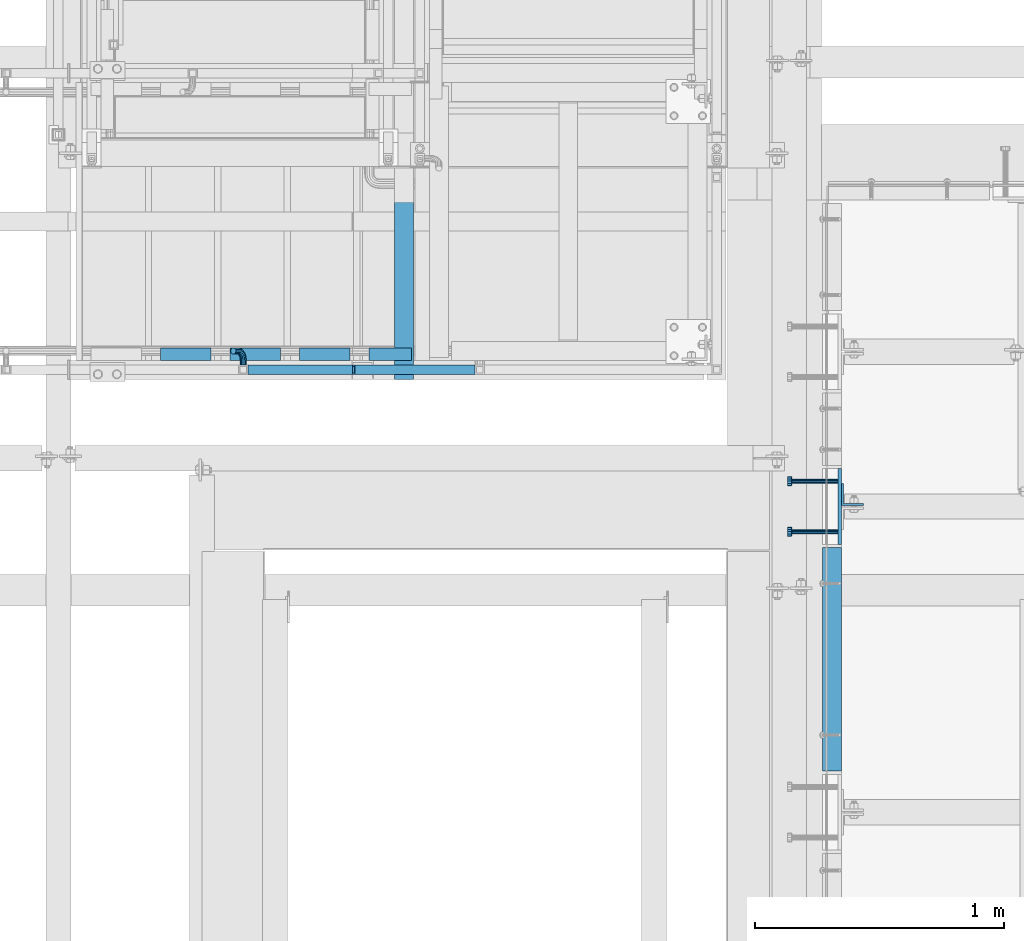
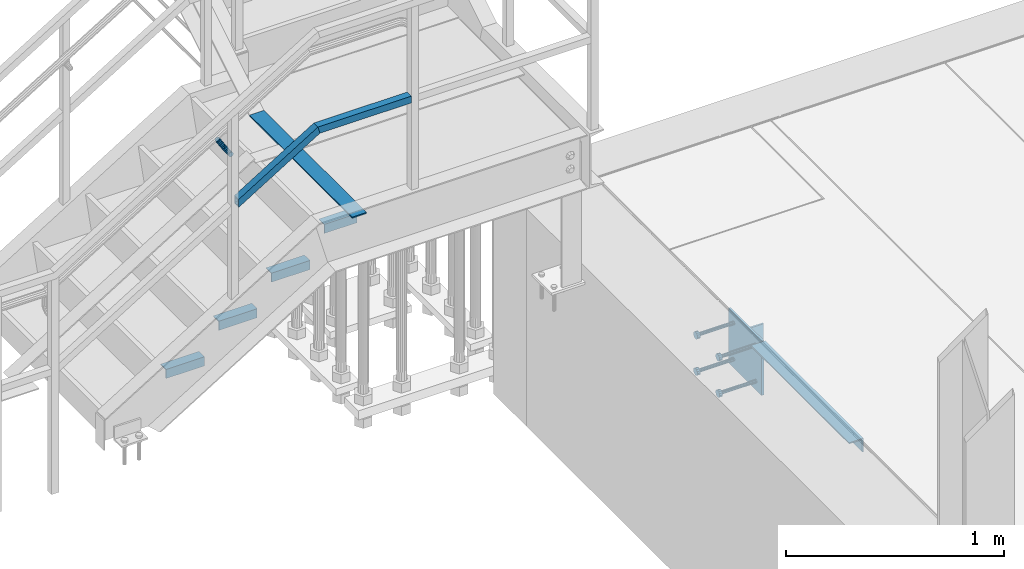
# One storey, part 2075 of 3843: 13 beams, 2 members, 6 elements without a shape of their own.
"""IFC2X3 building model written with IfcOpenShell, lengths in millimetres."""

from ifc_helpers import new_model, si_unit, frame, origin_with_axes, place, context, subcontext, project, spatial, faceted_brep, material, type_object, element, aggregate, save


model = new_model("IFC2X3")

# Units and contexts
model_context = context("Model", 3, precision=1e-05, world=origin_with_axes())
body_context = subcontext(model_context, "Body", "Model", "MODEL_VIEW")
ifc_project = project(units=[si_unit("LENGTHUNIT", "METRE", prefix="MILLI"), si_unit("AREAUNIT", "SQUARE_METRE"), si_unit("VOLUMEUNIT", "CUBIC_METRE"), si_unit("MASSUNIT", "GRAM", prefix="KILO"), si_unit("TIMEUNIT", "SECOND"), si_unit("PLANEANGLEUNIT", "RADIAN"), si_unit("SOLIDANGLEUNIT", "STERADIAN"), si_unit("THERMODYNAMICTEMPERATUREUNIT", "DEGREE_CELSIUS"), si_unit("LUMINOUSINTENSITYUNIT", "LUMEN")], contexts=[model_context])

# Site, building, storey
site_placement = place(None, origin_with_axes())
site = spatial("IfcSite", under=ifc_project, at=site_placement, CompositionType="ELEMENT")
building_placement = place(site_placement, origin_with_axes())
building = spatial("IfcBuilding", under=site, at=building_placement, Name="Undefined", CompositionType="ELEMENT")
storey_placement = place(building_placement, origin_with_axes())
storey = spatial("IfcBuildingStorey", under=building, at=storey_placement, Name="Undefined", CompositionType="ELEMENT", Elevation=0.0)

# Assembly, beam, member
assembly_1_placement = place(storey_placement, origin_with_axes())
assembly_1 = element("IfcElementAssembly", 1, at=assembly_1_placement, inside=storey, Name="RAIL", AssemblyPlace="NOTDEFINED", PredefinedType="RIGID_FRAME")
ifc_material_1 = material()
beam_type_1 = type_object("IfcBeamType", Name="HSS1-1/2X1-1/2X1/4", PredefinedType="NOTDEFINED")
beam_1_placement = place(assembly_1_placement, frame((54686.1999999943, 18008.6000001452, 31873.0923070972), z_axis=(0.0, 0.0, 1.0), x_axis=(-1.0, 0.0, 0.0)))
beam_1 = element("IfcBeam", 2, at=beam_1_placement, type_object=beam_type_1, material=ifc_material_1, Name="RAIL", ObjectType="HSS1-1/2X1-1/2X1/4", context=body_context, shape_type="Brep", body=[
    faceted_brep([(19.0499992350015, -19.0499992350015, -19.0499992350015), (19.0500015258804, 0.0, -19.0500000000029), (19.0499992350015, 19.0499992350015, -19.0499992350015), (502.608047339665, 19.0499992350015, -19.0499992350015), (502.608047339665, -19.0499992350015, -19.0499992350015), (19.0499992350015, -19.0499992350015, 19.0499992350015), (513.391954348786, -19.0499992350015, 19.0499992350015), (19.0499992350015, 19.0499992350015, 19.0499992350015), (19.0500015258804, 0.0, 19.0500000000029), (513.391954348786, 19.0499992350015, 19.0499992350015), (19.0499992350015, -12.6999993299978, 12.6999993299978), (19.0500015258731, 0.0, 12.6999999999971), (19.0499992350015, 12.6999993299978, 12.6999993299978), (511.594636468646, 12.6999993300014, 12.6999993300014), (511.594636468646, -12.6999993300014, 12.6999993300014), (19.0499992350015, -12.6999993299978, -12.6999993299978), (504.405365219805, -12.6999993300014, -12.6999993300014), (19.0499992350015, 12.6999993299978, -12.6999993299978), (19.0500015258731, 0.0, -12.6999999999971), (504.405365219805, 12.6999993300014, -12.6999993300014)], [[[0, 1, 2, 3, 4]], [[5, 0, 4, 6]], [[7, 8, 5, 6, 9]], [[2, 7, 9, 3]], [[10, 11, 12, 13, 14]], [[15, 10, 14, 16]], [[1, 0, 5, 8, 7, 2], [17, 12, 11, 10, 15, 18]], [[12, 17, 19, 13]], [[6, 4, 3, 9], [14, 13, 19, 16]], [[17, 18, 15, 16, 19]]]),
])
member_type_1 = type_object("IfcMemberType", Name="HSS1-1/2X1-1/2X1/4", PredefinedType="NOTDEFINED")
member_1_placement = place(assembly_1_placement, frame((53733.7000001369, 18008.6000001452, 31599.553846082), z_axis=(-0.524097425775922, 0.0, 0.851658316635875), x_axis=(0.851658316635872, 0.0, 0.524097425775926)))
member_1 = element("IfcMember", 3, at=member_1_placement, type_object=member_type_1, material=ifc_material_1, Name="RAIL", ObjectType="HSS1-1/2X1-1/2X1/4", context=body_context, shape_type="Brep", body=[
    faceted_brep([(10.6450480494532, -19.0499992350015, -19.0499992349796), (34.091200960931, -19.0499992350015, 19.0499992349942), (34.091200960931, 19.0499992350015, 19.0499992349942), (10.6450480494532, 19.0499992350015, -19.0499992349796), (30.1835087105574, 12.6999993300014, 12.6999993299978), (30.1835087105574, -12.6999993300014, 12.6999993299978), (14.5527402998268, -12.6999993300014, -12.6999993299833), (14.5527402998268, 12.6999993300014, -12.6999993299833), (516.530970655193, 19.0499992350015, -19.0499992347036), (516.530970655193, -19.0499992350015, -19.0499992347036), (527.31487768692, -19.0499992350015, 19.0499992352593), (527.31487768692, 19.0499992350015, 19.0499992352593), (525.517559803018, -12.6999993300014, 12.6999993302666), (525.517559803018, 12.6999993300014, 12.6999993302666), (518.328288539102, 12.6999993300014, -12.6999993297109), (518.328288539102, -12.6999993300014, -12.6999993297109)], [[[0, 1, 2, 3], [4, 5, 6, 7]], [[8, 9, 0, 3]], [[9, 10, 1, 0]], [[10, 11, 2, 1]], [[11, 8, 3, 2]], [[10, 9, 8, 11], [12, 13, 14, 15]], [[13, 12, 5, 4]], [[14, 13, 4, 7]], [[15, 14, 7, 6]], [[12, 15, 6, 5]]]),
])

# Assembly, beams
assembly_2_placement = place(storey_placement, origin_with_axes())
assembly_2 = element("IfcElementAssembly", 4, at=assembly_2_placement, inside=storey, Name="STAIR", AssemblyPlace="NOTDEFINED", PredefinedType="RIGID_FRAME")
ifc_material_2 = material(Name="STEEL/A36")
beam_type_2 = type_object("IfcBeamType", Name="L2X2X3/16", PredefinedType="NOTDEFINED")
beam_2_placement = place(assembly_2_placement, frame((54411.1640030385, 18072.1000001452, 31263.4923070946), z_axis=(0.0, 1.0, 0.0), x_axis=(-1.0, 0.0, 0.0)))
beam_2 = element("IfcBeam", 5, at=beam_2_placement, type_object=beam_type_2, material=ifc_material_2, Name="ANGLE", ObjectType="L2X2X3/16", context=body_context, shape_type="Brep", body=[
    faceted_brep([(0.0, 25.4000000000015, -25.4000000000015), (0.0, 25.4000000000015, 25.4000000000015), (171.449999999997, 25.4000000000015, 25.4000000000015), (171.449999999997, 25.4000000000015, -25.4000000000015), (0.0, 20.6375000000007, 25.4000000000015), (171.449999999997, 20.6375000000007, 25.4000000000015), (0.0, 20.6375000000007, -20.6375000000007), (171.449999999997, 20.6375000000007, -20.6375000000007), (0.0, -25.4000000000015, -20.6375000000007), (171.449999999997, -25.4000000000015, -20.6375000000007), (0.0, -25.4000000000015, -25.4000000000015), (171.449999999997, -25.4000000000015, -25.4000000000015)], [[[0, 1, 2, 3]], [[1, 4, 5, 2]], [[4, 6, 7, 5]], [[6, 8, 9, 7]], [[8, 10, 11, 9]], [[10, 0, 3, 11]], [[5, 7, 9, 11, 3, 2]], [[10, 8, 6, 4, 1, 0]]]),
])
beam_3_placement = place(assembly_2_placement, frame((54163.5140030364, 18072.1000001452, 31088.3788456762), z_axis=(0.0, 1.0, 0.0), x_axis=(-1.0, 0.0, 0.0)))
beam_3 = element("IfcBeam", 6, at=beam_3_placement, type_object=beam_type_2, material=ifc_material_2, Name="ANGLE", ObjectType="L2X2X3/16", context=body_context, shape_type="Brep", body=[
    faceted_brep([(0.0, 25.4000000000015, -25.4000000000015), (0.0, 25.4000000000015, 25.4000000000015), (203.199999999997, 25.4000000000015, 25.4000000000015), (203.199999999997, 25.4000000000015, -25.4000000000015), (0.0, 20.6375000000007, 25.4000000000015), (203.199999999997, 20.6375000000007, 25.4000000000015), (0.0, 20.6375000000007, -20.6375000000007), (203.199999999997, 20.6375000000007, -20.6375000000007), (0.0, -25.4000000000015, -20.6375000000007), (203.199999999997, -25.4000000000015, -20.6375000000007), (0.0, -25.4000000000015, -25.4000000000015), (203.199999999997, -25.4000000000015, -25.4000000000015)], [[[0, 1, 2, 3]], [[1, 4, 5, 2]], [[4, 6, 7, 5]], [[6, 8, 9, 7]], [[8, 10, 11, 9]], [[10, 0, 3, 11]], [[5, 7, 9, 11, 3, 2]], [[10, 8, 6, 4, 1, 0]]]),
])
beam_4_placement = place(assembly_2_placement, frame((53884.1140030351, 18072.1000001452, 30916.4403842572), z_axis=(0.0, 1.0, 0.0), x_axis=(-1.0, 0.0, 0.0)))
beam_4 = element("IfcBeam", 7, at=beam_4_placement, type_object=beam_type_2, material=ifc_material_2, Name="ANGLE", ObjectType="L2X2X3/16", context=body_context, shape_type="Brep", body=[
    faceted_brep([(0.0, 25.4000000000015, -25.4000000000015), (0.0, 25.4000000000015, 25.4000000000015), (203.199999999997, 25.4000000000015, 25.4000000000015), (203.199999999997, 25.4000000000015, -25.4000000000015), (0.0, 20.6375000000007, 25.4000000000015), (203.199999999997, 20.6375000000007, 25.4000000000015), (0.0, 20.6375000000007, -20.6375000000007), (203.199999999997, 20.6375000000007, -20.6375000000007), (0.0, -25.4000000000015, -20.6375000000007), (203.199999999997, -25.4000000000015, -20.6375000000007), (0.0, -25.4000000000015, -25.4000000000015), (203.199999999997, -25.4000000000015, -25.4000000000015)], [[[0, 1, 2, 3]], [[1, 4, 5, 2]], [[4, 6, 7, 5]], [[6, 8, 9, 7]], [[8, 10, 11, 9]], [[10, 0, 3, 11]], [[5, 7, 9, 11, 3, 2]], [[10, 8, 6, 4, 1, 0]]]),
])
beam_5_placement = place(assembly_2_placement, frame((53604.7140030339, 18072.1000001452, 30744.5019228381), z_axis=(0.0, 1.0, 0.0), x_axis=(-1.0, 0.0, 0.0)))
beam_5 = element("IfcBeam", 8, at=beam_5_placement, type_object=beam_type_2, material=ifc_material_2, Name="ANGLE", ObjectType="L2X2X3/16", context=body_context, shape_type="Brep", body=[
    faceted_brep([(0.0, 25.4000000000015, -25.4000000000015), (0.0, 25.4000000000015, 25.4000000000015), (203.199999999997, 25.4000000000015, 25.4000000000015), (203.199999999997, 25.4000000000015, -25.4000000000015), (0.0, 20.6375000000007, 25.4000000000015), (203.199999999997, 20.6375000000007, 25.4000000000015), (0.0, 20.6375000000007, -20.6375000000007), (203.199999999997, 20.6375000000007, -20.6375000000007), (0.0, -25.4000000000015, -20.6375000000007), (203.199999999997, -25.4000000000015, -20.6375000000007), (0.0, -25.4000000000015, -25.4000000000015), (203.199999999997, -25.4000000000015, -25.4000000000015)], [[[0, 1, 2, 3]], [[1, 4, 5, 2]], [[4, 6, 7, 5]], [[6, 8, 9, 7]], [[8, 10, 11, 9]], [[10, 0, 3, 11]], [[5, 7, 9, 11, 3, 2]], [[10, 8, 6, 4, 1, 0]]]),
])
aggregate(assembly_2, [beam_2, beam_3, beam_4, beam_5])

# Assembly, beam
assembly_3_placement = place(storey_placement, origin_with_axes())
assembly_3 = element("IfcElementAssembly", 9, at=assembly_3_placement, inside=storey, Name="EMBED PLATE", AssemblyPlace="NOTDEFINED", PredefinedType="RIGID_FRAME")
beam_type_3 = type_object("IfcBeamType", PredefinedType="NOTDEFINED")
beam_6_placement = place(assembly_3_placement, frame((56134.0000030517, 17459.325, 30422.85), z_axis=(0.0, 1.0, 0.0), x_axis=(0.0, 0.0, -1.0)))
beam_6 = element("IfcBeam", 10, at=beam_6_placement, type_object=beam_type_3, material=ifc_material_2, Name="EMBED PLATE", context=body_context, shape_type="Brep", body=[
    faceted_brep([(-1.0550138540566e-10, 6.34999999999854, -152.400000000664), (1.0550138540566e-10, 6.34999999999854, 152.400000000656), (304.799999999999, 6.34999999999854, 152.400000000001), (304.799999999999, 6.34999999999854, -152.400000000001), (1.0550138540566e-10, -6.34999999999854, 152.400000000656), (304.799999999999, -6.34999999999854, 152.400000000001), (-1.0550138540566e-10, -6.34999999999854, -152.400000000664), (304.799999999999, -6.34999999999854, -152.400000000001)], [[[0, 1, 2, 3]], [[1, 4, 5, 2]], [[4, 6, 7, 5]], [[6, 0, 3, 7]], [[5, 7, 3, 2]], [[6, 4, 1, 0]]]),
])

# Beam
beam_type_4 = type_object("IfcBeamType", PredefinedType="NOTDEFINED")
beam_7_placement = place(assembly_1_placement, frame((53734.2613426793, 18027.6500001452, 31869.0586597944), z_axis=(0.851658316635872, 0.0, 0.524097425775926), x_axis=(0.0, 1.0, 0.0)))
beam_7 = element("IfcBeam", 11, at=beam_7_placement, type_object=beam_type_4, material=ifc_material_2, Name="BRACKET ARM", context=body_context, shape_type="Brep", body=[
    faceted_brep([(0.0, -12.6999999999971, 0.0), (0.0, -10.9985226280696, -6.34999999999854), (19.0500015258731, -10.9985226280623, -6.34999999999854), (19.0500015258731, -12.6999999999971, -6.33008312433958e-10), (0.0, -6.35000000000582, -10.9985226280623), (19.0500015258731, -6.34999999999854, -10.9985226280623), (0.0, 0.0, -12.6999999999971), (19.0500015258731, 0.0, -12.6999999999971), (0.0, 6.35000000000582, -10.9985226280623), (19.0500015258731, 6.34999999999854, -10.9985226280623), (0.0, 10.9985226280696, -6.34999999999854), (19.0500015258731, 10.9985226280623, -6.34999999999854), (0.0, 12.6999999999971, 0.0), (19.0500015258731, 12.6999999999971, 0.0), (0.0, 10.9985226280696, 6.34999999999854), (19.0500015258731, 10.9985226280623, 6.34999999999854), (0.0, 6.35000000000582, 10.9985226280623), (19.0500015258731, 6.34999999999854, 10.9985226280623), (0.0, 0.0, 12.6999999999971), (19.0500015258731, 0.0, 12.6999999999971), (0.0, -6.35000000000582, 10.9985226280623), (19.0500015258731, -6.34999999999854, 10.9985226280623), (0.0, -10.9985226280696, 6.34999999999854), (19.0500015258731, -10.9985226280623, 6.34999999999854), (38.4903193060891, -8.8330803677236, -3.34694050252438e-10), (37.8391921052389, -7.26112024908798, 6.34999999974389), (36.0602795104642, -2.96644533684594, 10.9985226280041), (33.6302397149266, 2.90018969451194, 12.7000000002226), (31.2001999194181, 8.76682472604443, 10.9985226285644), (29.4212873247307, 13.061499638774, 6.35000000070431), (28.7701601240115, 14.6334597580644, 7.78527464717627e-10), (29.4212873248762, 13.0614996394288, -6.34999999929278), (31.2001999196509, 8.76682472718676, -10.9985226275603), (33.6302397151885, 2.90018969582889, -12.6999999997788), (36.0602795106824, -2.96644533571089, -10.9985226281206), (37.8391921053699, -7.26112024843314, -6.35000000026048), (53.7678987435793, 3.38210125690239, -6.3499999994383), (54.9710249311902, 2.17897506880399, 5.0931703299284e-10), (50.4808968708676, 6.66910312997061, -10.9985226273784), (45.9907688103704, 11.1592311906061, -12.6999999991458), (41.5006407498004, 15.6493592510378, -10.9985226270364), (38.213638876914, 18.9363611235749, -6.34999999884167), (37.0105126890558, 20.1394873109457, 1.20053300634027e-09), (38.2136388766667, 18.9363611228473, 6.35000000115542), (41.5006407493784, 15.6493592497718, 10.9985226290883), (45.9907688098756, 11.1592311891436, 12.7000000008557), (50.4808968704456, 6.66910312870459, 10.9985226287463), (53.7678987433319, 3.38210125617479, 6.35000000055879), (64.4111202489148, 19.3108078951118, -6.34999999821594), (65.9830803677178, 18.6596806939051, 1.77533365786076e-09), (60.1164453365491, 21.0897204901557, -10.9985226262725), (54.2498103051475, 23.5197602857806, -12.6999999981927), (48.3831752736587, 25.9498000811873, -10.9985226262434), (44.0885003610601, 27.7287126756128, -6.34999999817228), (42.516540241937, 28.3798398759754, 1.83354131877422e-09), (44.08850036074, 27.7287126747688, 6.35000000183209), (48.3831752731057, 25.9498000797321, 10.9985226298813), (54.2498103045073, 23.5197602840999, 12.7000000018088), (60.1164453359961, 21.0897204886933, 10.9985226298522), (64.4111202485947, 19.3108078942678, 6.35000000178115), (68.1485226282239, 38.0999984746086, -6.3499999967753), (69.8499999999913, 38.0999984741211, 2.92493496090174e-09), (63.500000000291, 38.0999984749651, -10.9985226249628), (57.1500000003434, 38.0999984750961, -12.6999999970722), (50.8000000002939, 38.0999984749651, -10.998522625312), (46.1514773720992, 38.0999984746086, -6.34999999737192), (44.4499999999971, 38.0999984741211, 2.58296495303512e-09), (46.1514773717645, 38.0999984736336, 6.35000000262517), (50.7999999996973, 38.0999984732771, 10.9985226308127), (57.1499999996449, 38.0999984731461, 12.700000002922), (63.4999999996944, 38.0999984732771, 10.9985226311619), (68.1485226278892, 38.0999984736336, 6.35000000322179), (68.1485226280638, 76.2000000002372, -6.34999999414867), (69.8499999999913, 76.199999999757, 5.84986992180347e-09), (63.5, 76.200000000601, -10.9985226222125), (57.1499999999942, 76.2000000007247, -12.6999999941472), (50.7999999999884, 76.200000000601, -10.9985226222125), (46.1514773719246, 76.2000000002372, -6.34999999414867), (44.4499999999971, 76.199999999757, 5.84986992180347e-09), (46.1514773719246, 76.1999999992695, 6.35000000584841), (50.7999999999884, 76.1999999989057, 10.9985226339122), (57.1499999999942, 76.199999998782, 12.700000005847), (63.5, 76.1999999989057, 10.9985226339122), (68.1485226280638, 76.1999999992695, 6.35000000584841)], [[[0, 1, 2, 3]], [[1, 4, 5, 2]], [[4, 6, 7, 5]], [[6, 8, 9, 7]], [[8, 10, 11, 9]], [[10, 12, 13, 11]], [[12, 14, 15, 13]], [[14, 16, 17, 15]], [[16, 18, 19, 17]], [[18, 20, 21, 19]], [[20, 22, 23, 21]], [[22, 0, 3, 23]], [[22, 20, 18, 16, 14, 12, 10, 8, 6, 4, 1, 0]], [[23, 3, 24, 25]], [[21, 23, 25, 26]], [[19, 21, 26, 27]], [[17, 19, 27, 28]], [[15, 17, 28, 29]], [[13, 15, 29, 30]], [[11, 13, 30, 31]], [[9, 11, 31, 32]], [[7, 9, 32, 33]], [[5, 7, 33, 34]], [[2, 5, 34, 35]], [[3, 2, 35, 24]], [[35, 36, 37, 24]], [[34, 38, 36, 35]], [[33, 39, 38, 34]], [[32, 40, 39, 33]], [[31, 41, 40, 32]], [[30, 42, 41, 31]], [[29, 43, 42, 30]], [[28, 44, 43, 29]], [[27, 45, 44, 28]], [[26, 46, 45, 27]], [[25, 47, 46, 26]], [[24, 37, 47, 25]], [[36, 48, 49, 37]], [[38, 50, 48, 36]], [[39, 51, 50, 38]], [[40, 52, 51, 39]], [[41, 53, 52, 40]], [[42, 54, 53, 41]], [[43, 55, 54, 42]], [[44, 56, 55, 43]], [[45, 57, 56, 44]], [[46, 58, 57, 45]], [[47, 59, 58, 46]], [[37, 49, 59, 47]], [[48, 60, 61, 49]], [[50, 62, 60, 48]], [[51, 63, 62, 50]], [[52, 64, 63, 51]], [[53, 65, 64, 52]], [[54, 66, 65, 53]], [[55, 67, 66, 54]], [[56, 68, 67, 55]], [[57, 69, 68, 56]], [[58, 70, 69, 57]], [[59, 71, 70, 58]], [[49, 61, 71, 59]], [[61, 60, 72, 73]], [[60, 62, 74, 72]], [[62, 63, 75, 74]], [[63, 64, 76, 75]], [[64, 65, 77, 76]], [[65, 66, 78, 77]], [[66, 67, 79, 78]], [[67, 68, 80, 79]], [[68, 69, 81, 80]], [[69, 70, 82, 81]], [[70, 71, 83, 82]], [[71, 61, 73, 83]], [[74, 75, 76, 77, 78, 79, 80, 81, 82, 83, 73, 72]]]),
])

aggregate(assembly_1, [beam_7, member_1, beam_1])

# Assembly, beam
assembly_4_placement = place(storey_placement, origin_with_axes())
assembly_4 = element("IfcElementAssembly", 12, at=assembly_4_placement, inside=storey, Name="ANGLE", AssemblyPlace="NOTDEFINED", PredefinedType="RIGID_FRAME")
beam_type_5 = type_object("IfcBeamType", Name="L3X3X1/4", PredefinedType="NOTDEFINED")
beam_8_placement = place(assembly_4_placement, frame((56102.2499946952, 16394.1123697409, 30391.1000045777), z_axis=(0.0, 0.0, -1.0), x_axis=(0.0, 1.0, 0.0)))
beam_8 = element("IfcBeam", 13, at=beam_8_placement, type_object=beam_type_5, material=ifc_material_2, Name="ANGLE", ObjectType="L3X3X1/4", context=body_context, shape_type="Brep", body=[
    faceted_brep([(0.0, 38.0999999999985, -38.0999999999985), (0.0, 38.0999999999985, 38.0999999999985), (900.112000000037, 38.1000000023996, 38.0999999999985), (900.112000000037, 38.1000000023996, -38.0999999999985), (0.0, 31.75, 38.0999999999985), (900.11200000003, 31.7500000023938, 38.0999999999985), (0.0, 31.75, -31.75), (900.11200000003, 31.7500000023938, -31.75), (0.0, -38.0999999999985, -31.75), (900.111999999965, -38.0999999976048, -31.75), (0.0, -38.0999999999985, -38.0999999999985), (900.111999999965, -38.0999999976048, -38.0999999999985)], [[[0, 1, 2, 3]], [[1, 4, 5, 2]], [[4, 6, 7, 5]], [[6, 8, 9, 7]], [[8, 10, 11, 9]], [[10, 0, 3, 11]], [[5, 7, 9, 11, 3, 2]], [[10, 8, 6, 4, 1, 0]]]),
])
aggregate(assembly_4, [beam_8])

# Assembly, member
assembly_5_placement = place(storey_placement, origin_with_axes())
assembly_5 = element("IfcElementAssembly", 14, at=assembly_5_placement, inside=storey, Name="ref.", AssemblyPlace="NOTDEFINED", PredefinedType="RIGID_FRAME")
ifc_material_3 = material(Name="STEEL/Steel_Undefined")
member_type_2 = type_object("IfcMemberType", PredefinedType="NOTDEFINED")
member_2_placement = place(assembly_5_placement, frame((54381.4, 18912.6357261783, 31336.517307097), z_axis=(1.0, 0.0, 0.0), x_axis=(0.0, -1.0, 0.0)))
member_2 = element("IfcMember", 15, at=member_2_placement, type_object=member_type_2, material=ifc_material_3, Name="ref.", context=body_context, shape_type="Brep", body=[
    faceted_brep([(0.0, 3.17500000000291, -38.0999999999985), (0.0, 3.17500000000291, 38.0999999999985), (942.135726113924, 3.17499999999927, 38.0999999999985), (942.135726113924, 3.17499999999927, -38.0999999999985), (0.0, -3.17500000000291, 38.0999999999985), (942.135726113924, -3.17499999999927, 38.0999999999985), (0.0, -3.17500000000291, -38.0999999999985), (942.135726113924, -3.17499999999927, -38.0999999999985)], [[[0, 1, 2, 3]], [[1, 4, 5, 2]], [[4, 6, 7, 5]], [[6, 0, 3, 7]], [[5, 7, 3, 2]], [[6, 4, 1, 0]]]),
])
aggregate(assembly_5, [member_2])

# Assembly, beam
assembly_6_placement = place(storey_placement, origin_with_axes())
assembly_6 = element("IfcElementAssembly", 16, at=assembly_6_placement, inside=storey, Name="BEAM", AssemblyPlace="NOTDEFINED", PredefinedType="RIGID_FRAME")
beam_type_6 = type_object("IfcBeamType", Name="L3-1/2X3-1/2X3/8", PredefinedType="NOTDEFINED")
beam_9_placement = place(assembly_6_placement, frame((56184.8000030518, 17506.95, 30391.1), z_axis=(0.0, 1.0, 0.0), x_axis=(0.0, 0.0, -1.0)))
beam_9 = element("IfcBeam", 17, at=beam_9_placement, type_object=beam_type_6, material=ifc_material_2, Name="ANGLE", ObjectType="L3-1/2X3-1/2X3/8", context=body_context, shape_type="Brep", body=[
    faceted_brep([(-3.63797880709171e-12, 44.4499999999971, -44.4500000000007), (-3.63797880709171e-12, 44.4499999999971, 44.4500000000007), (228.600000000006, 44.4499999999971, 44.4500000000007), (228.600000000006, 44.4499999999971, -44.4500000000007), (0.0, 34.9250000000029, 44.4500000000007), (228.600000000006, 34.9250000000029, 44.4500000000007), (0.0, 34.9250000000029, -34.9250000000029), (228.600000000006, 34.9250000000029, -34.9249999999993), (0.0, -44.4499999999971, -34.9249999999993), (228.600000000006, -44.4499999999971, -34.9249999999993), (3.63797880709171e-12, -44.4499999999971, -44.4500000000007), (228.600000000006, -44.4499999999971, -44.4500000000007)], [[[0, 1, 2, 3]], [[1, 4, 5, 2]], [[4, 6, 7, 5]], [[6, 8, 9, 7]], [[8, 10, 11, 9]], [[10, 0, 3, 11]], [[5, 7, 9, 11, 3, 2]], [[10, 8, 6, 4, 1, 0]]]),
])
aggregate(assembly_6, [beam_9])

# Beam
ifc_material_4 = material(Name="STEEL/A108")
beam_type_7 = type_object("IfcBeamType", PredefinedType="NOTDEFINED")
beam_10_placement = place(assembly_3_placement, frame((56127.6500030517, 17357.725, 30372.05), z_axis=(0.0, -1.0, 0.0), x_axis=(-1.0, 0.0, 0.0)))
beam_10 = element("IfcBeam", 18, at=beam_10_placement, type_object=beam_type_7, material=ifc_material_4, Name="HEADED STUD ANCHOR", context=body_context, shape_type="Brep", body=[
    faceted_brep([(0.0, -9.52000045776367, 0.0), (0.0, -8.25, -4.76000022888184), (184.912000000004, -8.25, -4.76000022888184), (184.912000000004, -9.52000045776367, 0.0), (0.0, -4.76000022888184, -8.25), (184.912000000004, -4.76000022888184, -8.25), (0.0, 0.0, -9.52000045776367), (184.912000000004, 0.0, -9.52000045776367), (0.0, 4.76000022888184, -8.25), (184.912000000004, 4.76000022888184, -8.25), (0.0, 8.25, -4.76000022888184), (184.912000000004, 8.25, -4.76000022888184), (0.0, 9.52000045776367, 0.0), (184.912000000004, 9.52000045776367, 0.0), (0.0, 8.25, 4.76000022888184), (184.912000000004, 8.25, 4.76000022888184), (0.0, 4.76000022888184, 8.25), (184.912000000004, 4.76000022888184, 8.25), (0.0, 0.0, 9.52000045776367), (184.912000000004, 0.0, 9.52000045776367), (0.0, -4.76000022888184, 8.25), (184.912000000004, -4.76000022888184, 8.25), (0.0, -8.25, 4.76000022888184), (184.912000000004, -8.25, 4.76000022888184), (186.944000000003, -16.5, -9.52000045776367), (186.944000000003, -19.0499992370605, 0.0), (186.944000000003, -9.52000045776367, -16.5), (186.944000000003, 0.0, -19.0499992370605), (186.944000000003, 9.52000045776367, -16.5), (186.944000000003, 16.5, -9.52000045776367), (186.944000000003, 19.0499992370605, 0.0), (186.944000000003, 16.5, 9.52000045776367), (186.944000000003, 9.52000045776367, 16.5), (186.944000000003, 0.0, 19.0499992370605), (186.944000000003, -9.52000045776367, 16.5), (186.944000000003, -16.5, 9.52000045776367), (203.199999999997, -16.5, -9.52000045776367), (203.199999999997, -19.0499992370605, 0.0), (203.199999999997, -9.52000045776367, -16.5), (203.199999999997, 0.0, -19.0499992370605), (203.199999999997, 9.52000045776367, -16.5), (203.199999999997, 16.5, -9.52000045776367), (203.199999999997, 19.0499992370605, 0.0), (203.199999999997, 16.5, 9.52000045776367), (203.199999999997, 9.52000045776367, 16.5), (203.199999999997, 0.0, 19.0499992370605), (203.199999999997, -9.52000045776367, 16.5), (203.199999999997, -16.5, 9.52000045776367)], [[[0, 1, 2, 3]], [[1, 4, 5, 2]], [[4, 6, 7, 5]], [[6, 8, 9, 7]], [[8, 10, 11, 9]], [[10, 12, 13, 11]], [[12, 14, 15, 13]], [[14, 16, 17, 15]], [[16, 18, 19, 17]], [[18, 20, 21, 19]], [[20, 22, 23, 21]], [[22, 0, 3, 23]], [[22, 20, 18, 16, 14, 12, 10, 8, 6, 4, 1, 0]], [[3, 2, 24, 25]], [[2, 5, 26, 24]], [[5, 7, 27, 26]], [[7, 9, 28, 27]], [[9, 11, 29, 28]], [[11, 13, 30, 29]], [[13, 15, 31, 30]], [[15, 17, 32, 31]], [[17, 19, 33, 32]], [[19, 21, 34, 33]], [[21, 23, 35, 34]], [[23, 3, 25, 35]], [[25, 24, 36, 37]], [[24, 26, 38, 36]], [[26, 27, 39, 38]], [[27, 28, 40, 39]], [[28, 29, 41, 40]], [[29, 30, 42, 41]], [[30, 31, 43, 42]], [[31, 32, 44, 43]], [[32, 33, 45, 44]], [[33, 34, 46, 45]], [[34, 35, 47, 46]], [[35, 25, 37, 47]], [[38, 39, 40, 41, 42, 43, 44, 45, 46, 47, 37, 36]]]),
])

beam_11_placement = place(assembly_3_placement, frame((56127.6500030517, 17357.725, 30168.85), z_axis=(0.0, -1.0, 0.0), x_axis=(-1.0, 0.0, 0.0)))
beam_11 = element("IfcBeam", 19, at=beam_11_placement, type_object=beam_type_7, material=ifc_material_4, Name="HEADED STUD ANCHOR", context=body_context, shape_type="Brep", body=[
    faceted_brep([(0.0, -9.52000045776367, 0.0), (0.0, -8.25, -4.76000022888184), (184.912000000004, -8.25, -4.76000022888184), (184.912000000004, -9.52000045776367, 0.0), (0.0, -4.76000022888184, -8.25), (184.912000000004, -4.76000022888184, -8.25), (0.0, 0.0, -9.52000045776367), (184.912000000004, 0.0, -9.52000045776367), (0.0, 4.76000022888184, -8.25), (184.912000000004, 4.76000022888184, -8.25), (0.0, 8.25, -4.76000022888184), (184.912000000004, 8.25, -4.76000022888184), (0.0, 9.52000045776367, 0.0), (184.912000000004, 9.52000045776367, 0.0), (0.0, 8.25, 4.76000022888184), (184.912000000004, 8.25, 4.76000022888184), (0.0, 4.76000022888184, 8.25), (184.912000000004, 4.76000022888184, 8.25), (0.0, 0.0, 9.52000045776367), (184.912000000004, 0.0, 9.52000045776367), (0.0, -4.76000022888184, 8.25), (184.912000000004, -4.76000022888184, 8.25), (0.0, -8.25, 4.76000022888184), (184.912000000004, -8.25, 4.76000022888184), (186.944000000003, -16.5, -9.52000045776367), (186.944000000003, -19.0499992370605, 0.0), (186.944000000003, -9.52000045776367, -16.5), (186.944000000003, 0.0, -19.0499992370605), (186.944000000003, 9.52000045776367, -16.5), (186.944000000003, 16.5, -9.52000045776367), (186.944000000003, 19.0499992370605, 0.0), (186.944000000003, 16.5, 9.52000045776367), (186.944000000003, 9.52000045776367, 16.5), (186.944000000003, 0.0, 19.0499992370605), (186.944000000003, -9.52000045776367, 16.5), (186.944000000003, -16.5, 9.52000045776367), (203.199999999997, -16.5, -9.52000045776367), (203.199999999997, -19.0499992370605, 0.0), (203.199999999997, -9.52000045776367, -16.5), (203.199999999997, 0.0, -19.0499992370605), (203.199999999997, 9.52000045776367, -16.5), (203.199999999997, 16.5, -9.52000045776367), (203.199999999997, 19.0499992370605, 0.0), (203.199999999997, 16.5, 9.52000045776367), (203.199999999997, 9.52000045776367, 16.5), (203.199999999997, 0.0, 19.0499992370605), (203.199999999997, -9.52000045776367, 16.5), (203.199999999997, -16.5, 9.52000045776367)], [[[0, 1, 2, 3]], [[1, 4, 5, 2]], [[4, 6, 7, 5]], [[6, 8, 9, 7]], [[8, 10, 11, 9]], [[10, 12, 13, 11]], [[12, 14, 15, 13]], [[14, 16, 17, 15]], [[16, 18, 19, 17]], [[18, 20, 21, 19]], [[20, 22, 23, 21]], [[22, 0, 3, 23]], [[22, 20, 18, 16, 14, 12, 10, 8, 6, 4, 1, 0]], [[3, 2, 24, 25]], [[2, 5, 26, 24]], [[5, 7, 27, 26]], [[7, 9, 28, 27]], [[9, 11, 29, 28]], [[11, 13, 30, 29]], [[13, 15, 31, 30]], [[15, 17, 32, 31]], [[17, 19, 33, 32]], [[19, 21, 34, 33]], [[21, 23, 35, 34]], [[23, 3, 25, 35]], [[25, 24, 36, 37]], [[24, 26, 38, 36]], [[26, 27, 39, 38]], [[27, 28, 40, 39]], [[28, 29, 41, 40]], [[29, 30, 42, 41]], [[30, 31, 43, 42]], [[31, 32, 44, 43]], [[32, 33, 45, 44]], [[33, 34, 46, 45]], [[34, 35, 47, 46]], [[35, 25, 37, 47]], [[38, 39, 40, 41, 42, 43, 44, 45, 46, 47, 37, 36]]]),
])

beam_12_placement = place(assembly_3_placement, frame((56127.6500030517, 17560.925, 30372.05), z_axis=(0.0, -1.0, 0.0), x_axis=(-1.0, 0.0, 0.0)))
beam_12 = element("IfcBeam", 20, at=beam_12_placement, type_object=beam_type_7, material=ifc_material_2, Name="PLATE", context=body_context, shape_type="Brep", body=[
    faceted_brep([(0.0, -9.52000045776367, 0.0), (0.0, -8.25, -4.76000022888184), (184.912000000004, -8.25, -4.76000022888184), (184.912000000004, -9.52000045776367, 0.0), (0.0, -4.76000022888184, -8.25), (184.912000000004, -4.76000022888184, -8.25), (0.0, 0.0, -9.52000045776367), (184.912000000004, 0.0, -9.52000045776367), (0.0, 4.76000022888184, -8.25), (184.912000000004, 4.76000022888184, -8.25), (0.0, 8.25, -4.76000022888184), (184.912000000004, 8.25, -4.76000022888184), (0.0, 9.52000045776367, 0.0), (184.912000000004, 9.52000045776367, 0.0), (0.0, 8.25, 4.76000022888184), (184.912000000004, 8.25, 4.76000022888184), (0.0, 4.76000022888184, 8.25), (184.912000000004, 4.76000022888184, 8.25), (0.0, 0.0, 9.52000045776367), (184.912000000004, 0.0, 9.52000045776367), (0.0, -4.76000022888184, 8.25), (184.912000000004, -4.76000022888184, 8.25), (0.0, -8.25, 4.76000022888184), (184.912000000004, -8.25, 4.76000022888184), (186.944000000003, -16.5, -9.52000045776367), (186.944000000003, -19.0499992370605, 0.0), (186.944000000003, -9.52000045776367, -16.5), (186.944000000003, 0.0, -19.0499992370605), (186.944000000003, 9.52000045776367, -16.5), (186.944000000003, 16.5, -9.52000045776367), (186.944000000003, 19.0499992370605, 0.0), (186.944000000003, 16.5, 9.52000045776367), (186.944000000003, 9.52000045776367, 16.5), (186.944000000003, 0.0, 19.0499992370605), (186.944000000003, -9.52000045776367, 16.5), (186.944000000003, -16.5, 9.52000045776367), (203.199999999997, -16.5, -9.52000045776367), (203.199999999997, -19.0499992370605, 0.0), (203.199999999997, -9.52000045776367, -16.5), (203.199999999997, 0.0, -19.0499992370605), (203.199999999997, 9.52000045776367, -16.5), (203.199999999997, 16.5, -9.52000045776367), (203.199999999997, 19.0499992370605, 0.0), (203.199999999997, 16.5, 9.52000045776367), (203.199999999997, 9.52000045776367, 16.5), (203.199999999997, 0.0, 19.0499992370605), (203.199999999997, -9.52000045776367, 16.5), (203.199999999997, -16.5, 9.52000045776367)], [[[0, 1, 2, 3]], [[1, 4, 5, 2]], [[4, 6, 7, 5]], [[6, 8, 9, 7]], [[8, 10, 11, 9]], [[10, 12, 13, 11]], [[12, 14, 15, 13]], [[14, 16, 17, 15]], [[16, 18, 19, 17]], [[18, 20, 21, 19]], [[20, 22, 23, 21]], [[22, 0, 3, 23]], [[22, 20, 18, 16, 14, 12, 10, 8, 6, 4, 1, 0]], [[3, 2, 24, 25]], [[2, 5, 26, 24]], [[5, 7, 27, 26]], [[7, 9, 28, 27]], [[9, 11, 29, 28]], [[11, 13, 30, 29]], [[13, 15, 31, 30]], [[15, 17, 32, 31]], [[17, 19, 33, 32]], [[19, 21, 34, 33]], [[21, 23, 35, 34]], [[23, 3, 25, 35]], [[25, 24, 36, 37]], [[24, 26, 38, 36]], [[26, 27, 39, 38]], [[27, 28, 40, 39]], [[28, 29, 41, 40]], [[29, 30, 42, 41]], [[30, 31, 43, 42]], [[31, 32, 44, 43]], [[32, 33, 45, 44]], [[33, 34, 46, 45]], [[34, 35, 47, 46]], [[35, 25, 37, 47]], [[38, 39, 40, 41, 42, 43, 44, 45, 46, 47, 37, 36]]]),
])

beam_13_placement = place(assembly_3_placement, frame((56127.6500030517, 17560.925, 30168.85), z_axis=(0.0, -1.0, 0.0), x_axis=(-1.0, 0.0, 0.0)))
beam_13 = element("IfcBeam", 21, at=beam_13_placement, type_object=beam_type_7, material=ifc_material_4, Name="HEADED STUD ANCHOR", context=body_context, shape_type="Brep", body=[
    faceted_brep([(0.0, -9.52000045776367, 0.0), (0.0, -8.25, -4.76000022888184), (184.912000000004, -8.25, -4.76000022888184), (184.912000000004, -9.52000045776367, 0.0), (0.0, -4.76000022888184, -8.25), (184.912000000004, -4.76000022888184, -8.25), (0.0, 0.0, -9.52000045776367), (184.912000000004, 0.0, -9.52000045776367), (0.0, 4.76000022888184, -8.25), (184.912000000004, 4.76000022888184, -8.25), (0.0, 8.25, -4.76000022888184), (184.912000000004, 8.25, -4.76000022888184), (0.0, 9.52000045776367, 0.0), (184.912000000004, 9.52000045776367, 0.0), (0.0, 8.25, 4.76000022888184), (184.912000000004, 8.25, 4.76000022888184), (0.0, 4.76000022888184, 8.25), (184.912000000004, 4.76000022888184, 8.25), (0.0, 0.0, 9.52000045776367), (184.912000000004, 0.0, 9.52000045776367), (0.0, -4.76000022888184, 8.25), (184.912000000004, -4.76000022888184, 8.25), (0.0, -8.25, 4.76000022888184), (184.912000000004, -8.25, 4.76000022888184), (186.944000000003, -16.5, -9.52000045776367), (186.944000000003, -19.0499992370605, 0.0), (186.944000000003, -9.52000045776367, -16.5), (186.944000000003, 0.0, -19.0499992370605), (186.944000000003, 9.52000045776367, -16.5), (186.944000000003, 16.5, -9.52000045776367), (186.944000000003, 19.0499992370605, 0.0), (186.944000000003, 16.5, 9.52000045776367), (186.944000000003, 9.52000045776367, 16.5), (186.944000000003, 0.0, 19.0499992370605), (186.944000000003, -9.52000045776367, 16.5), (186.944000000003, -16.5, 9.52000045776367), (203.199999999997, -16.5, -9.52000045776367), (203.199999999997, -19.0499992370605, 0.0), (203.199999999997, -9.52000045776367, -16.5), (203.199999999997, 0.0, -19.0499992370605), (203.199999999997, 9.52000045776367, -16.5), (203.199999999997, 16.5, -9.52000045776367), (203.199999999997, 19.0499992370605, 0.0), (203.199999999997, 16.5, 9.52000045776367), (203.199999999997, 9.52000045776367, 16.5), (203.199999999997, 0.0, 19.0499992370605), (203.199999999997, -9.52000045776367, 16.5), (203.199999999997, -16.5, 9.52000045776367)], [[[0, 1, 2, 3]], [[1, 4, 5, 2]], [[4, 6, 7, 5]], [[6, 8, 9, 7]], [[8, 10, 11, 9]], [[10, 12, 13, 11]], [[12, 14, 15, 13]], [[14, 16, 17, 15]], [[16, 18, 19, 17]], [[18, 20, 21, 19]], [[20, 22, 23, 21]], [[22, 0, 3, 23]], [[22, 20, 18, 16, 14, 12, 10, 8, 6, 4, 1, 0]], [[3, 2, 24, 25]], [[2, 5, 26, 24]], [[5, 7, 27, 26]], [[7, 9, 28, 27]], [[9, 11, 29, 28]], [[11, 13, 30, 29]], [[13, 15, 31, 30]], [[15, 17, 32, 31]], [[17, 19, 33, 32]], [[19, 21, 34, 33]], [[21, 23, 35, 34]], [[23, 3, 25, 35]], [[25, 24, 36, 37]], [[24, 26, 38, 36]], [[26, 27, 39, 38]], [[27, 28, 40, 39]], [[28, 29, 41, 40]], [[29, 30, 42, 41]], [[30, 31, 43, 42]], [[31, 32, 44, 43]], [[32, 33, 45, 44]], [[33, 34, 46, 45]], [[34, 35, 47, 46]], [[35, 25, 37, 47]], [[38, 39, 40, 41, 42, 43, 44, 45, 46, 47, 37, 36]]]),
])

aggregate(assembly_3, [beam_10, beam_11, beam_12, beam_13, beam_6])

save(model, "model.ifc")
